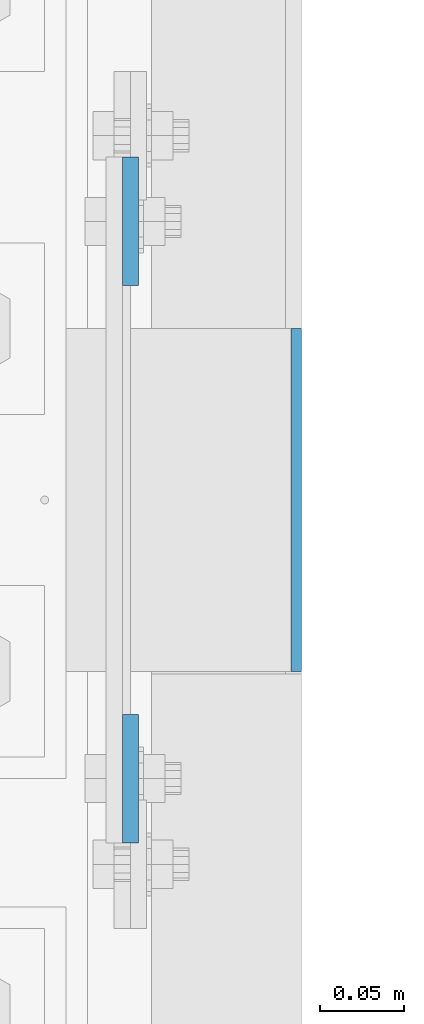
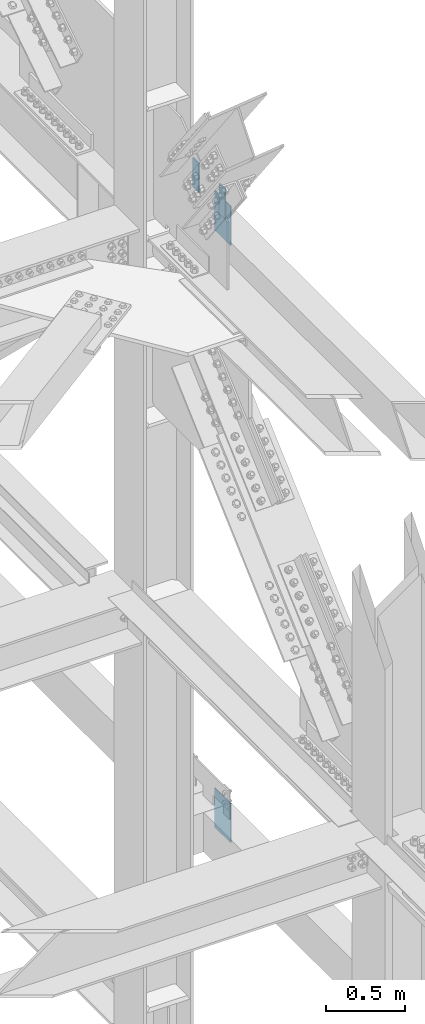
# One storey, part 1642 of 3843: 4 columns, 3 elements without a shape of their own.
"""IFC2X3 building model written with IfcOpenShell, lengths in millimetres."""

from ifc_helpers import new_model, si_unit, frame, origin_with_axes, place, context, subcontext, project, spatial, faceted_brep, material, type_object, element, aggregate, save


model = new_model("IFC2X3")

# Units and contexts
model_context = context("Model", 3, precision=1e-05, world=origin_with_axes())
body_context = subcontext(model_context, "Body", "Model", "MODEL_VIEW")
ifc_project = project(units=[si_unit("LENGTHUNIT", "METRE", prefix="MILLI"), si_unit("AREAUNIT", "SQUARE_METRE"), si_unit("VOLUMEUNIT", "CUBIC_METRE"), si_unit("MASSUNIT", "GRAM", prefix="KILO"), si_unit("TIMEUNIT", "SECOND"), si_unit("PLANEANGLEUNIT", "RADIAN"), si_unit("SOLIDANGLEUNIT", "STERADIAN"), si_unit("THERMODYNAMICTEMPERATUREUNIT", "DEGREE_CELSIUS"), si_unit("LUMINOUSINTENSITYUNIT", "LUMEN")], contexts=[model_context])

# Site, building, storey
site_placement = place(None, origin_with_axes())
site = spatial("IfcSite", under=ifc_project, at=site_placement, CompositionType="ELEMENT")
building_placement = place(site_placement, origin_with_axes())
building = spatial("IfcBuilding", under=site, at=building_placement, Name="Undefined", CompositionType="ELEMENT")
storey_placement = place(building_placement, origin_with_axes())
storey = spatial("IfcBuildingStorey", under=building, at=storey_placement, Name="Undefined", CompositionType="ELEMENT", Elevation=0.0)

# Assembly, columns
assembly_1_placement = place(storey_placement, origin_with_axes())
assembly_1 = element("IfcElementAssembly", 1, at=assembly_1_placement, inside=storey, Name="COLUMN", AssemblyPlace="NOTDEFINED", PredefinedType="RIGID_FRAME")
ifc_material = material(Name="STEEL/A572-50")
column_type_1 = type_object("IfcColumnType", PredefinedType="NOTDEFINED")
column_1_placement = place(assembly_1_placement, frame((86153.625, 92214.7, 42062.4), z_axis=(0.0, 1.0, 0.0), x_axis=(0.0, 0.0, 1.0)))
column_1 = element("IfcColumn", 2, at=column_1_placement, type_object=column_type_1, material=ifc_material, Name="PLATE", context=body_context, shape_type="Brep", body=[
    faceted_brep([(0.0, 3.17499999999927, -101.600000000006), (0.0, 3.17499999999927, 101.600000000006), (304.800000000003, 3.17499999999927, 101.600000000006), (304.800000000003, 3.17499999999927, -101.600000000006), (0.0, -3.17499999999927, 101.600000000006), (304.800000000003, -3.17499999999927, 101.600000000006), (0.0, -3.17499999999927, -101.600000000006), (304.800000000003, -3.17499999999927, -101.600000000006)], [[[0, 1, 2, 3]], [[1, 4, 5, 2]], [[4, 6, 7, 5]], [[6, 0, 3, 7]], [[5, 7, 3, 2]], [[6, 4, 1, 0]]]),
])
column_2_placement = place(assembly_1_placement, frame((86153.625, 92214.7, 37439.6), z_axis=(0.0, 1.0, 0.0), x_axis=(0.0, 0.0, 1.0)))
column_2 = element("IfcColumn", 3, at=column_2_placement, type_object=column_type_1, material=ifc_material, Name="PLATE", context=body_context, shape_type="Brep", body=[
    faceted_brep([(0.0, 3.17499999999927, -101.600000000006), (0.0, 3.17499999999927, 101.600000000006), (304.800000000003, 3.17499999999927, 101.600000000006), (304.800000000003, 3.17499999999927, -101.600000000006), (0.0, -3.17499999999927, 101.600000000006), (304.800000000003, -3.17499999999927, 101.600000000006), (0.0, -3.17499999999927, -101.600000000006), (304.800000000003, -3.17499999999927, -101.600000000006)], [[[0, 1, 2, 3]], [[1, 4, 5, 2]], [[4, 6, 7, 5]], [[6, 0, 3, 7]], [[5, 7, 3, 2]], [[6, 4, 1, 0]]]),
])
aggregate(assembly_1, [column_1, column_2])

# Assembly, column
assembly_2_placement = place(storey_placement, origin_with_axes())
assembly_2 = element("IfcElementAssembly", 4, at=assembly_2_placement, inside=storey, Name="GIRT", AssemblyPlace="NOTDEFINED", PredefinedType="RIGID_FRAME")
column_type_2 = type_object("IfcColumnType", PredefinedType="NOTDEFINED")
column_3_placement = place(assembly_2_placement, frame((86055.2, 92379.8, 42367.2), z_axis=(0.0, 1.0, 0.0), x_axis=(0.0, 0.0, 1.0)))
column_3 = element("IfcColumn", 5, at=column_3_placement, type_object=column_type_2, material=ifc_material, Name="PLATE", context=body_context, shape_type="Brep", body=[
    faceted_brep([(0.0, 4.76250000000073, -38.0999999999985), (0.0, 4.76250000000073, 38.0999999999985), (228.599999999999, 4.76249999999709, 38.1000000000058), (228.599999999999, 4.76249999999709, -38.1000000000058), (0.0, -4.76250000000073, 38.0999999999985), (228.599999999999, -4.76249999999709, 38.1000000000058), (0.0, -4.76250000000073, -38.0999999999985), (228.599999999999, -4.76249999999709, -38.1000000000058)], [[[0, 1, 2, 3]], [[1, 4, 5, 2]], [[4, 6, 7, 5]], [[6, 0, 3, 7]], [[5, 7, 3, 2]], [[6, 4, 1, 0]]]),
])
aggregate(assembly_2, [column_3])

assembly_3_placement = place(storey_placement, origin_with_axes())
assembly_3 = element("IfcElementAssembly", 6, at=assembly_3_placement, inside=storey, Name="GIRT", AssemblyPlace="NOTDEFINED", PredefinedType="RIGID_FRAME")
column_4_placement = place(assembly_3_placement, frame((86055.2, 92049.6, 42367.2), z_axis=(0.0, 1.0, 0.0), x_axis=(0.0, 0.0, 1.0)))
column_4 = element("IfcColumn", 7, at=column_4_placement, type_object=column_type_2, material=ifc_material, Name="PLATE", context=body_context, shape_type="Brep", body=[
    faceted_brep([(0.0, 4.76250000000073, -38.0999999999985), (0.0, 4.76250000000073, 38.0999999999985), (228.599999999999, 4.76249999999709, 38.1000000000058), (228.599999999999, 4.76249999999709, -38.1000000000058), (0.0, -4.76250000000073, 38.0999999999985), (228.599999999999, -4.76249999999709, 38.1000000000058), (0.0, -4.76250000000073, -38.0999999999985), (228.599999999999, -4.76249999999709, -38.1000000000058)], [[[0, 1, 2, 3]], [[1, 4, 5, 2]], [[4, 6, 7, 5]], [[6, 0, 3, 7]], [[5, 7, 3, 2]], [[6, 4, 1, 0]]]),
])
aggregate(assembly_3, [column_4])

save(model, "model.ifc")
